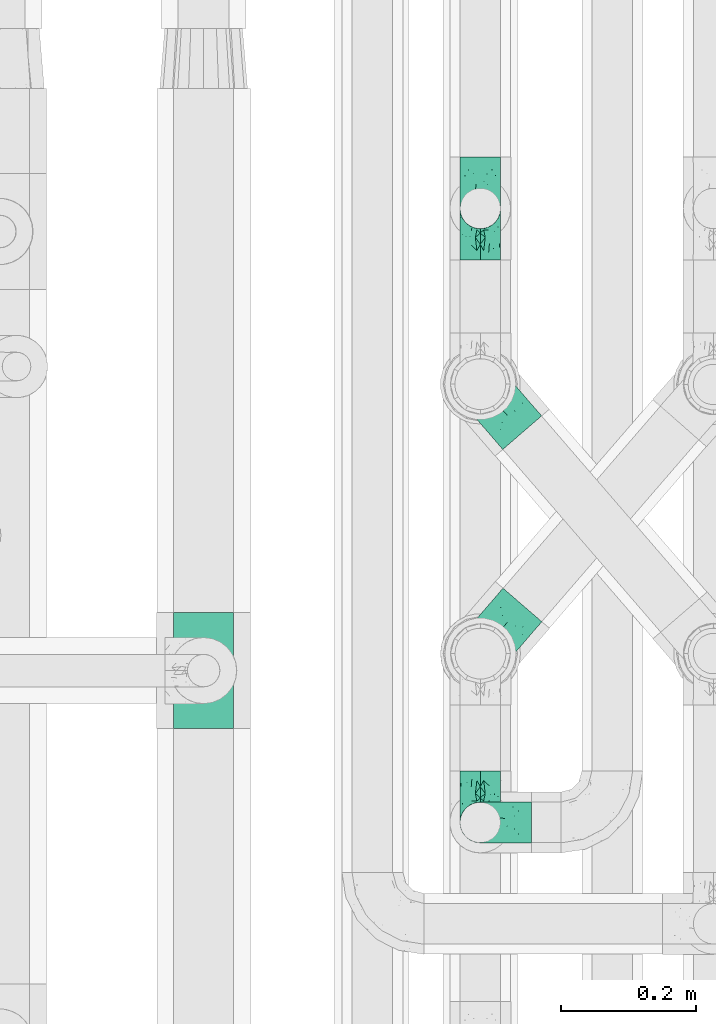
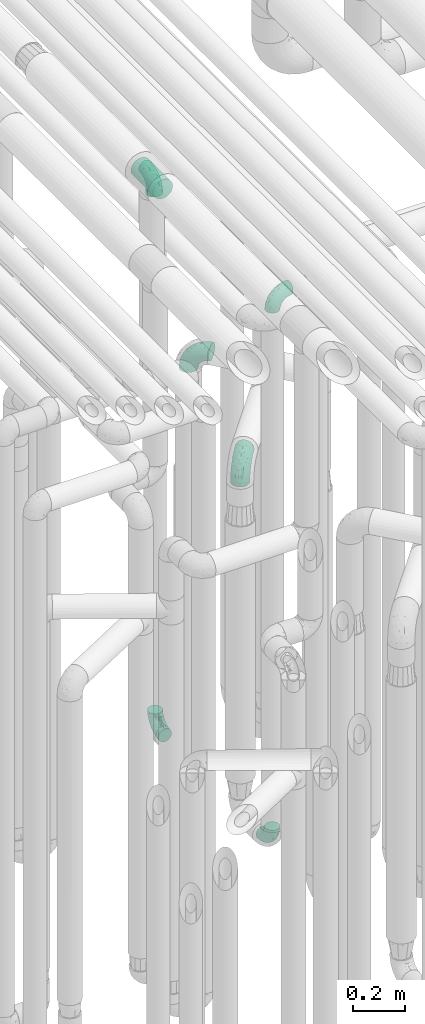
# One storey, part 623 of 827: 7 flow fittings.
"""IFC2X3 building model written with IfcOpenShell, lengths in millimetres."""

from ifc_helpers import new_model, entity, si_unit, converted_unit, derived_unit, direction, frame, origin, place, context, subcontext, project, spatial, faceted_brep, source, transform, mapped, material, type_object, type_shapes, element, save


model = new_model("IFC2X3")

# Units and contexts
model_context = context("Model", 3, precision=0.01, world=origin(), true_north=direction((6.12303176911189e-17, 1.0)))
body_context = subcontext(model_context, "Body", "Model", "MODEL_VIEW")
ifc_project = project(units=[si_unit("LENGTHUNIT", "METRE", prefix="MILLI"), si_unit("AREAUNIT", "SQUARE_METRE"), si_unit("VOLUMEUNIT", "CUBIC_METRE"), converted_unit("PLANEANGLEUNIT", "DEGREE", entity("IfcRatioMeasure", 0.0174532925199433), si_unit("PLANEANGLEUNIT", "RADIAN"), dimensions=[0, 0, 0, 0, 0, 0, 0]), si_unit("MASSUNIT", "GRAM", prefix="KILO"), derived_unit("MASSDENSITYUNIT", [(si_unit("MASSUNIT", "GRAM", prefix="KILO"), 1), (si_unit("LENGTHUNIT", "METRE"), -3)]), derived_unit("MOMENTOFINERTIAUNIT", [(si_unit("LENGTHUNIT", "METRE"), 4)]), si_unit("TIMEUNIT", "SECOND"), si_unit("FREQUENCYUNIT", "HERTZ"), si_unit("THERMODYNAMICTEMPERATUREUNIT", "DEGREE_CELSIUS"), derived_unit("THERMALTRANSMITTANCEUNIT", [(si_unit("MASSUNIT", "GRAM", prefix="KILO"), 1), (si_unit("THERMODYNAMICTEMPERATUREUNIT", "KELVIN"), -1), (si_unit("TIMEUNIT", "SECOND"), -3)]), derived_unit("VOLUMETRICFLOWRATEUNIT", [(si_unit("LENGTHUNIT", "METRE"), 3), (si_unit("TIMEUNIT", "SECOND"), -1)]), derived_unit("MASSFLOWRATEUNIT", [(si_unit("MASSUNIT", "GRAM", prefix="KILO"), 1), (si_unit("TIMEUNIT", "SECOND"), -1)]), derived_unit("ROTATIONALFREQUENCYUNIT", [(si_unit("TIMEUNIT", "SECOND"), -1)]), si_unit("ELECTRICCURRENTUNIT", "AMPERE"), si_unit("ELECTRICVOLTAGEUNIT", "VOLT"), si_unit("POWERUNIT", "WATT"), si_unit("FORCEUNIT", "NEWTON", prefix="KILO"), si_unit("ILLUMINANCEUNIT", "LUX"), si_unit("LUMINOUSFLUXUNIT", "LUMEN"), si_unit("LUMINOUSINTENSITYUNIT", "CANDELA"), derived_unit("USERDEFINED", [(si_unit("MASSUNIT", "GRAM", prefix="KILO"), -1), (si_unit("LENGTHUNIT", "METRE"), -2), (si_unit("TIMEUNIT", "SECOND"), 3), (si_unit("LUMINOUSFLUXUNIT", "LUMEN"), 1)]), derived_unit("LINEARVELOCITYUNIT", [(si_unit("LENGTHUNIT", "METRE"), 1), (si_unit("TIMEUNIT", "SECOND"), -1)]), si_unit("PRESSUREUNIT", "PASCAL"), derived_unit("USERDEFINED", [(si_unit("LENGTHUNIT", "METRE"), -2), (si_unit("MASSUNIT", "GRAM", prefix="KILO"), 1), (si_unit("TIMEUNIT", "SECOND"), -2)]), derived_unit("LINEARFORCEUNIT", [(si_unit("MASSUNIT", "GRAM", prefix="KILO"), 1), (si_unit("LENGTHUNIT", "METRE"), 1), (si_unit("TIMEUNIT", "SECOND"), -2), (si_unit("LENGTHUNIT", "METRE"), -1)]), derived_unit("PLANARFORCEUNIT", [(si_unit("MASSUNIT", "GRAM", prefix="KILO"), 1), (si_unit("LENGTHUNIT", "METRE"), 1), (si_unit("TIMEUNIT", "SECOND"), -2), (si_unit("LENGTHUNIT", "METRE"), -2)])], contexts=[model_context])

# Site, building, storey
site_placement = place(None, origin())
site = spatial("IfcSite", under=ifc_project, at=site_placement, CompositionType="ELEMENT")
building_placement = place(site_placement, origin())
building = spatial("IfcBuilding", under=site, at=building_placement, CompositionType="ELEMENT")
storey_placement = place(building_placement, frame((0.0, 0.0, 28200.0)))
storey = spatial("IfcBuildingStorey", under=building, at=storey_placement, Name="08", CompositionType="ELEMENT", Elevation=28200.0)

# Flow fittings
ifc_material = material()
pipe_fitting_type_1 = type_object("IfcPipeFittingType", Name="ADSK_1", PredefinedType="NOTDEFINED", material=ifc_material)
shared_shape_1 = source(origin(), body_context, "Body", "Brep", [
    faceted_brep([(-76.0, 15.07, -26.11), (-76.0, 7.8, -29.12), (-76.0, 0.0, -30.15), (-76.0, -7.8, -29.12), (-76.0, -15.08, -26.11), (-76.0, -21.32, -21.32), (-76.0, -26.11, -15.08), (-76.0, -29.12, -7.8), (-76.0, -30.15, 0.0), (-76.0, -29.12, 7.8), (-76.0, -26.11, 15.07), (-76.0, -21.32, 21.32), (-76.0, -15.08, 26.11), (-76.0, -7.8, 29.12), (-76.0, 0.0, 30.15), (-76.0, 7.8, 29.12), (-76.0, 15.07, 26.11), (-76.0, 21.32, 21.32), (-76.0, 26.11, 15.07), (-76.0, 29.12, 7.8), (-76.0, 30.15, 0.0), (-76.0, 29.12, -7.8), (-76.0, 26.11, -15.08), (-76.0, 21.32, -21.32), (0.0, 76.0, -30.15), (-7.8, 76.0, -29.12), (-15.07, 76.0, -26.11), (-21.32, 76.0, -21.32), (-26.11, 76.0, -15.08), (-29.12, 76.0, -7.8), (-30.15, 76.0, 0.0), (-29.12, 76.0, 7.8), (-26.11, 76.0, 15.07), (-21.32, 76.0, 21.32), (-15.07, 76.0, 26.11), (-7.8, 76.0, 29.12), (0.0, 76.0, 30.15), (7.8, 76.0, 29.12), (15.08, 76.0, 26.11), (21.32, 76.0, 21.32), (26.11, 76.0, 15.07), (29.12, 76.0, 7.8), (30.15, 76.0, 0.0), (29.12, 76.0, -7.8), (26.11, 76.0, -15.08), (21.32, 76.0, -21.32), (15.08, 76.0, -26.11), (7.8, 76.0, -29.12), (10.79, 31.43, 21.07), (4.32, 31.7, 25.72), (1.65, 15.19, 19.92), (-61.17, -27.8, 0.0), (-51.1, -25.49, 9.84), (-56.14, -10.61, 27.27), (-31.7, -4.32, 25.72), (-39.75, 1.72, 29.41), (-43.2, -24.95, 0.0), (-1.86, 1.86, 0.0), (4.49, 7.65, 5.78), (-7.82, -4.61, 5.83), (-56.21, -22.79, 17.21), (-58.98, -3.38, 29.7), (-53.96, 5.6, 30.07), (-10.86, 10.86, 25.48), (-17.2, -2.6, 20.44), (-49.15, -16.01, 22.7), (-22.18, -14.24, 7.99), (-28.4, -17.42, 0.0), (-13.61, -9.88, 0.0), (-39.0, 23.48, 27.76), (-58.76, 12.54, 28.36), (-41.61, 15.41, 29.48), (16.01, 49.15, 22.7), (-58.55, 25.93, 19.53), (-51.53, 33.5, 13.51), (-64.92, 28.76, 12.4), (-7.48, 23.14, 28.25), (-1.72, 39.75, 29.41), (-12.04, 27.88, 29.88), (-63.91, 18.81, 24.52), (-11.63, 65.16, 28.18), (-4.97, 57.02, 30.05), (9.88, 13.61, 0.0), (-62.5, 31.74, 5.02), (-45.17, 30.98, 21.2), (-21.78, 9.76, 28.58), (10.61, 56.14, 27.27), (-32.09, 54.42, 13.26), (22.79, 56.21, 17.21), (15.38, 31.17, 15.63), (25.49, 51.1, 9.84), (21.84, 36.35, 5.92), (24.95, 43.2, 0.0), (3.38, 58.98, 29.7), (-31.17, -15.38, 15.63), (-39.39, 41.78, 15.45), (-34.56, 41.13, 20.79), (-39.81, -23.25, 5.49), (27.8, 61.17, 0.0), (-31.74, 62.5, 5.02), (-53.07, 36.29, 0.0), (-42.95, 42.95, 7.29), (-36.29, 53.07, 0.0), (-19.83, 58.51, 24.79), (-25.48, 60.2, 19.41), (-14.53, 50.96, 28.57), (-13.31, 37.09, 30.07), (-26.16, 40.06, 26.4), (-32.43, -10.35, 21.9), (17.42, 28.4, 0.0), (14.24, 22.18, 7.99), (-38.67, 9.72, 30.15), (-24.66, 17.36, 30.09), (-37.08, 31.49, 24.99), (-49.27, 22.83, 25.24), (-20.8, 38.81, 28.63), (-27.58, 27.58, 29.2), (-36.07, -20.23, 10.71), (-15.19, -6.16, 14.9), (6.6, 15.4, 14.49), (-2.51, 2.51, 11.35), (-65.16, 11.63, -28.18), (-49.15, -16.01, -22.7), (-57.02, 4.97, -30.05), (-25.93, 58.55, -19.53), (-33.5, 51.53, -13.51), (-28.76, 64.92, -12.4), (-60.2, 25.48, -19.41), (-58.51, 19.83, -24.79), (4.61, 7.82, -5.83), (-7.65, -4.49, -5.78), (-2.51, 2.51, -11.35), (-62.5, 31.74, -5.02), (-50.96, 14.53, -28.57), (-37.09, 13.31, -30.07), (-42.95, 42.95, -7.29), (25.49, 51.1, -9.84), (22.79, 56.21, -17.21), (-40.06, 26.16, -26.4), (3.38, 58.98, -29.7), (-5.6, 53.96, -30.07), (-27.88, 12.04, -29.88), (-9.76, 21.78, -28.58), (-23.14, 7.48, -28.25), (-51.1, -25.49, -9.84), (15.38, 31.17, -15.63), (16.01, 49.15, -22.7), (-23.48, 39.0, -27.76), (-12.54, 58.76, -28.36), (-15.41, 41.61, -29.48), (-56.21, -22.79, -17.21), (-9.72, 38.67, -30.15), (-17.36, 24.66, -30.09), (-22.18, -14.24, -7.99), (-41.13, 34.56, -20.79), (-31.74, 62.5, -5.02), (-58.98, -3.38, -29.7), (-31.17, -15.38, -15.63), (-56.14, -10.61, -27.27), (14.24, 22.18, -7.99), (23.25, 39.81, -5.49), (-31.49, 37.08, -24.99), (-15.19, -6.16, -14.9), (1.65, 15.19, -19.92), (-18.81, 63.91, -24.52), (-32.59, -11.62, -20.84), (-31.7, -4.32, -25.72), (-17.2, -2.6, -20.44), (-39.75, 1.72, -29.41), (-54.42, 32.09, -13.26), (-30.98, 45.17, -21.2), (10.61, 56.14, -27.27), (10.23, 31.31, -21.52), (4.32, 31.7, -25.72), (-41.78, 39.39, -15.45), (-1.72, 39.75, -29.41), (-36.35, -21.84, -5.92), (-22.83, 49.27, -25.24), (-38.81, 20.8, -28.63), (-27.58, 27.58, -29.2), (-10.86, 10.86, -25.48), (20.23, 36.07, -10.71), (6.6, 15.4, -14.49)], [[[0, 1, 2, 3, 4, 5, 6, 7, 8, 9, 10, 11, 12, 13, 14, 15, 16, 17, 18, 19, 20, 21, 22, 23]], [[24, 25, 26, 27, 28, 29, 30, 31, 32, 33, 34, 35, 36, 37, 38, 39, 40, 41, 42, 43, 44, 45, 46, 47]], [[48, 49, 50]], [[51, 52, 9]], [[53, 54, 55]], [[9, 52, 10]], [[56, 52, 51]], [[57, 58, 59]], [[11, 10, 60]], [[14, 61, 62]], [[63, 54, 64]], [[65, 12, 11]], [[65, 53, 12]], [[66, 67, 68]], [[69, 70, 71]], [[72, 39, 38]], [[73, 74, 75]], [[15, 70, 16]], [[76, 77, 78]], [[16, 79, 17]], [[13, 61, 14]], [[35, 80, 81]], [[14, 62, 15]], [[17, 73, 18]], [[57, 82, 58]], [[20, 19, 83]], [[75, 19, 18]], [[70, 15, 62]], [[73, 84, 74]], [[78, 85, 76]], [[38, 86, 72]], [[32, 31, 87]], [[88, 89, 90]], [[91, 92, 90]], [[72, 86, 49]], [[36, 93, 37]], [[75, 83, 19]], [[36, 35, 81]], [[60, 94, 65]], [[40, 90, 41]], [[95, 96, 87]], [[88, 90, 40]], [[66, 97, 67]], [[90, 98, 41]], [[40, 39, 88]], [[99, 31, 30]], [[20, 83, 100]], [[101, 102, 100]], [[52, 60, 10]], [[102, 99, 30]], [[96, 103, 104]], [[83, 101, 100]], [[12, 53, 13]], [[104, 103, 33]], [[105, 106, 81]], [[107, 105, 103]], [[64, 54, 108]], [[80, 103, 105]], [[80, 35, 34]], [[34, 33, 103]], [[86, 38, 37]], [[109, 110, 82]], [[71, 111, 112]], [[69, 107, 113]], [[79, 73, 17]], [[114, 113, 84]], [[33, 32, 104]], [[115, 107, 116]], [[105, 115, 106]], [[93, 81, 77]], [[54, 53, 65]], [[61, 53, 55]], [[108, 94, 64]], [[54, 63, 85]], [[93, 86, 37]], [[77, 76, 49]], [[77, 49, 86]], [[49, 63, 50]], [[60, 52, 117]], [[65, 11, 60]], [[39, 72, 88]], [[89, 88, 72]], [[71, 70, 62]], [[79, 70, 114]], [[103, 96, 107]], [[69, 113, 114]], [[112, 106, 116]], [[77, 81, 106]], [[112, 116, 71]], [[112, 55, 85]], [[64, 50, 63]], [[57, 59, 68]], [[32, 87, 104]], [[96, 104, 87]], [[94, 118, 64]], [[50, 119, 89]], [[50, 64, 118]], [[50, 89, 48]], [[81, 93, 36]], [[86, 93, 77]], [[53, 61, 13]], [[62, 61, 55]], [[71, 62, 111]], [[69, 71, 116]], [[95, 101, 74]], [[99, 101, 87]], [[118, 66, 59]], [[117, 97, 66]], [[117, 66, 94]], [[91, 89, 110]], [[91, 110, 109]], [[110, 89, 119]], [[9, 8, 51]], [[98, 90, 92]], [[98, 42, 41]], [[101, 83, 74]], [[101, 99, 102]], [[87, 31, 99]], [[62, 55, 111]], [[55, 112, 111]], [[107, 69, 116]], [[70, 69, 114]], [[107, 96, 113]], [[84, 113, 96]], [[84, 96, 95]], [[114, 84, 73]], [[70, 79, 16]], [[73, 79, 114]], [[54, 85, 55]], [[76, 85, 63]], [[49, 76, 63]], [[77, 106, 78]], [[106, 112, 78]], [[85, 78, 112]], [[73, 75, 18]], [[83, 75, 74]], [[103, 80, 34]], [[81, 80, 105]], [[101, 95, 87]], [[84, 95, 74]], [[106, 115, 116]], [[105, 107, 115]], [[120, 59, 58]], [[82, 110, 58]], [[119, 58, 110]], [[118, 59, 120]], [[66, 68, 59]], [[54, 65, 108]], [[94, 108, 65]], [[66, 118, 94]], [[50, 118, 120]], [[50, 120, 119]], [[119, 120, 58]], [[89, 72, 48]], [[49, 48, 72]], [[60, 117, 94]], [[117, 52, 97]], [[52, 56, 97]], [[67, 97, 56]], [[92, 91, 109]], [[89, 91, 90]], [[121, 1, 0]], [[122, 5, 4]], [[2, 1, 123]], [[124, 125, 126]], [[127, 128, 23]], [[129, 130, 131]], [[100, 132, 20]], [[133, 134, 123]], [[135, 100, 102]], [[136, 137, 44]], [[133, 128, 138]], [[24, 139, 140]], [[141, 142, 143]], [[121, 128, 133]], [[6, 144, 7]], [[137, 145, 146]], [[144, 51, 7]], [[147, 148, 149]], [[144, 6, 150]], [[149, 151, 152]], [[153, 68, 67]], [[154, 128, 127]], [[30, 155, 102]], [[43, 42, 98]], [[156, 3, 2]], [[157, 144, 150]], [[158, 4, 3]], [[24, 140, 25]], [[155, 135, 102]], [[159, 160, 109]], [[30, 29, 155]], [[147, 138, 161]], [[27, 124, 28]], [[57, 129, 82]], [[162, 163, 131]], [[27, 26, 164]], [[148, 26, 25]], [[165, 166, 167]], [[24, 47, 139]], [[143, 168, 141]], [[22, 21, 169]], [[125, 124, 170]], [[148, 25, 140]], [[46, 146, 171]], [[158, 122, 4]], [[0, 23, 128]], [[1, 121, 123]], [[109, 82, 159]], [[45, 44, 137]], [[146, 46, 45]], [[136, 43, 98]], [[132, 21, 20]], [[136, 98, 92]], [[172, 173, 146]], [[46, 171, 47]], [[43, 136, 44]], [[174, 154, 169]], [[171, 173, 175]], [[6, 5, 150]], [[126, 29, 28]], [[176, 56, 144]], [[122, 158, 166]], [[164, 124, 27]], [[177, 161, 170]], [[23, 22, 127]], [[178, 138, 179]], [[133, 178, 134]], [[156, 123, 168]], [[156, 158, 3]], [[168, 143, 166]], [[168, 166, 158]], [[166, 180, 167]], [[173, 171, 146]], [[139, 171, 175]], [[172, 145, 163]], [[173, 180, 142]], [[5, 122, 150]], [[157, 150, 122]], [[137, 136, 181]], [[146, 45, 137]], [[149, 148, 140]], [[164, 148, 177]], [[128, 154, 138]], [[147, 161, 177]], [[152, 134, 179]], [[168, 123, 134]], [[152, 179, 149]], [[152, 175, 142]], [[57, 130, 129]], [[157, 165, 167]], [[22, 169, 127]], [[154, 127, 169]], [[163, 167, 180]], [[162, 157, 167]], [[173, 163, 180]], [[182, 163, 145]], [[123, 156, 2]], [[158, 156, 168]], [[171, 139, 47]], [[140, 139, 175]], [[149, 140, 151]], [[147, 149, 179]], [[174, 135, 125]], [[132, 135, 169]], [[176, 157, 153]], [[176, 153, 67]], [[153, 157, 162]], [[182, 159, 129]], [[181, 160, 159]], [[181, 159, 145]], [[51, 144, 56]], [[51, 8, 7]], [[135, 132, 100]], [[169, 21, 132]], [[126, 155, 29]], [[135, 155, 125]], [[140, 175, 151]], [[175, 152, 151]], [[138, 147, 179]], [[148, 147, 177]], [[138, 154, 161]], [[170, 161, 154]], [[170, 154, 174]], [[177, 170, 124]], [[148, 164, 26]], [[124, 164, 177]], [[173, 142, 175]], [[143, 142, 180]], [[166, 143, 180]], [[168, 134, 141]], [[134, 152, 141]], [[142, 141, 152]], [[124, 126, 28]], [[155, 126, 125]], [[128, 121, 0]], [[123, 121, 133]], [[135, 174, 169]], [[170, 174, 125]], [[134, 178, 179]], [[133, 138, 178]], [[130, 153, 162]], [[68, 153, 130]], [[57, 68, 130]], [[182, 129, 131]], [[159, 82, 129]], [[157, 122, 165]], [[166, 165, 122]], [[163, 162, 167]], [[162, 131, 130]], [[145, 172, 146]], [[163, 173, 172]], [[159, 182, 145]], [[131, 163, 182]], [[56, 176, 67]], [[157, 176, 144]], [[137, 181, 145]], [[181, 136, 160]], [[136, 92, 160]], [[109, 160, 92]]]),
])
type_shapes(pipe_fitting_type_1, [shared_shape_1])
for number, where, z_axis, x_axis, name in (
    (1, (36629.64, 13240.2, 3000.0), (1.0, 0.0, 0.0), (0.0, -1.0, 0.0), "ADSK_1"),
    (2, (36629.64, 13240.2, 400.0), (-1.0, 0.0, 0.0), (0.0, 0.0, -1.0), "ADSK_1"),
    (3, (36629.64, 12331.17, 400.0), (-1.0, 0.0, 0.0), (0.0, -1.0, 0.0), "ADSK_1"),
    (4, (36629.64, 12331.17, 3000.0), (0.0, -1.0, 0.0), (-1.0, 0.0, 0.0), "ADSK_1"),
):
    element("IfcFlowFitting", number, at=place(storey_placement, frame(where, z_axis=z_axis, x_axis=x_axis)), inside=storey, type_object=pipe_fitting_type_1, material=ifc_material, Name=name, ObjectType="ADSK_1", context=body_context, shape_type="MappedRepresentation", body=[
        mapped(shared_shape_1, transform((0.0, 0.0, 0.0), scale=1.0)),
    ])
pipe_fitting_type_2 = type_object("IfcPipeFittingType", Name="ADSK_1", PredefinedType="NOTDEFINED", material=ifc_material)
shared_shape_2 = source(origin(), body_context, "Body", "Brep", [
    faceted_brep([(-95.0, 19.02, -32.95), (-95.0, 9.85, -36.75), (-95.0, 0.0, -38.05), (-95.0, -9.85, -36.75), (-95.0, -19.03, -32.95), (-95.0, -26.91, -26.91), (-95.0, -32.95, -19.03), (-95.0, -36.75, -9.85), (-95.0, -38.05, 0.0), (-95.0, -36.75, 9.85), (-95.0, -32.95, 19.02), (-95.0, -26.91, 26.91), (-95.0, -19.03, 32.95), (-95.0, -9.85, 36.75), (-95.0, 0.0, 38.05), (-95.0, 9.85, 36.75), (-95.0, 19.02, 32.95), (-95.0, 26.91, 26.91), (-95.0, 32.95, 19.02), (-95.0, 36.75, 9.85), (-95.0, 38.05, 0.0), (-95.0, 36.75, -9.85), (-95.0, 32.95, -19.03), (-95.0, 26.91, -26.91), (0.0, 95.0, -38.05), (-9.85, 95.0, -36.75), (-19.02, 95.0, -32.95), (-26.91, 95.0, -26.91), (-32.95, 95.0, -19.03), (-36.75, 95.0, -9.85), (-38.05, 95.0, 0.0), (-36.75, 95.0, 9.85), (-32.95, 95.0, 19.02), (-26.91, 95.0, 26.91), (-19.02, 95.0, 32.95), (-9.85, 95.0, 36.75), (0.0, 95.0, 38.05), (9.85, 95.0, 36.75), (19.03, 95.0, 32.95), (26.91, 95.0, 26.91), (32.95, 95.0, 19.02), (36.75, 95.0, 9.85), (38.05, 95.0, 0.0), (36.75, 95.0, -9.85), (32.95, 95.0, -19.03), (26.91, 95.0, -26.91), (19.03, 95.0, -32.95), (9.85, 95.0, -36.75), (-7.99, -4.96, 6.3), (-0.92, 0.92, 0.0), (4.62, 8.1, 8.01), (-76.19, -35.57, 0.0), (-64.32, -32.32, 12.43), (20.51, 62.45, 28.68), (-60.56, -33.52, 0.0), (-70.4, -13.47, 34.42), (-39.61, -5.88, 32.32), (-49.6, 2.07, 37.1), (-70.34, -28.81, 21.71), (14.64, 40.81, 26.5), (5.88, 39.61, 32.32), (3.59, 20.77, 25.31), (-40.45, 68.06, 16.75), (-62.45, -20.51, 28.68), (-44.52, -26.87, 0.0), (-28.47, -20.22, 0.0), (-26.43, -17.83, 8.75), (-76.1, 39.63, 10.76), (-72.74, 37.58, 18.19), (-60.35, 46.18, 14.61), (-13.4, 13.4, 32.12), (-20.77, -3.59, 25.31), (-14.66, 81.47, 35.56), (-6.22, 71.26, 37.92), (-57.5, 42.48, 22.79), (-15.0, 34.74, 37.7), (-27.1, 12.08, 36.05), (-9.2, 28.81, 35.63), (-79.98, 23.7, 30.95), (-73.68, -4.3, 37.48), (-30.74, 21.67, 37.97), (-62.36, 47.59, 6.79), (-72.71, 32.83, 24.69), (-67.42, 7.02, 37.95), (-32.13, 75.27, 24.51), (-43.46, 51.47, 26.26), (-24.98, 73.15, 31.29), (20.59, 41.28, 19.85), (7.79, 16.09, 15.86), (-73.21, 42.39, 0.0), (-54.73, 54.73, 0.0), (-73.44, 15.79, 35.79), (-5.94, 4.32, 20.43), (28.81, 70.34, 21.71), (32.32, 64.32, 12.43), (-53.59, 26.2, 35.09), (-52.02, 19.31, 37.21), (21.38, 33.53, 10.34), (26.87, 44.52, 0.0), (-48.28, 12.14, 38.05), (4.3, 73.68, 37.48), (-44.08, -25.52, 12.79), (-41.28, -20.59, 19.85), (35.57, 76.19, 0.0), (-47.26, 54.3, 20.18), (-47.4, 61.99, 8.58), (-42.39, 73.21, 0.0), (-39.67, 78.86, 7.21), (-45.69, 36.84, 33.11), (-32.83, 50.13, 33.35), (13.47, 70.4, 34.42), (-18.25, 63.73, 36.07), (-40.63, -13.75, 27.22), (-16.63, 46.37, 37.95), (-53.47, 38.79, 28.59), (-26.07, 48.54, 36.15), (-34.51, 34.51, 36.86), (-2.07, 49.6, 37.1), (-22.79, -10.49, 19.23), (-61.73, 28.67, 31.87), (9.65, 14.7, 0.0), (20.22, 28.47, 0.0), (33.52, 60.56, 0.0), (-11.42, -5.44, 13.25), (-14.7, -9.65, 0.0), (-81.47, 14.66, -35.56), (-62.45, -20.51, -28.68), (-71.26, 6.22, -37.92), (-75.27, 32.13, -24.51), (-73.15, 24.98, -31.29), (13.47, 70.4, -34.42), (5.88, 39.61, -32.32), (-2.07, 49.6, -37.1), (-78.86, 39.67, -7.21), (-70.4, -13.47, -34.42), (-39.61, -5.88, -32.32), (-61.99, 47.4, -8.58), (32.32, 64.32, -12.43), (28.81, 70.34, -21.71), (-63.73, 18.25, -36.07), (-50.13, 32.83, -33.35), (4.3, 73.68, -37.48), (-7.02, 67.42, -37.95), (-39.63, 76.1, -10.76), (-46.18, 60.35, -14.61), (-47.59, 62.36, -6.79), (-64.32, -32.32, -12.43), (-26.2, 53.59, -35.09), (-15.79, 73.44, -35.79), (-19.31, 52.02, -37.21), (-37.58, 72.74, -18.19), (-70.34, -28.81, -21.71), (-42.48, 57.5, -22.79), (-38.79, 53.47, -28.59), (-51.47, 43.46, -26.26), (-32.83, 72.71, -24.69), (-46.37, 16.63, -37.95), (-73.68, -4.3, -37.48), (-41.28, -20.59, -19.85), (-44.08, -25.52, -12.79), (13.75, 40.63, -27.22), (20.51, 62.45, -28.68), (-68.06, 40.45, -16.75), (-54.3, 47.26, -20.18), (-12.14, 48.28, -38.05), (-21.67, 30.74, -37.97), (-36.84, 45.69, -33.11), (-11.42, -5.44, -13.25), (7.79, 16.09, -15.86), (4.62, 8.1, -8.01), (-23.7, 79.98, -30.95), (-26.43, -17.83, -8.75), (-7.99, -4.96, -6.3), (-40.81, -14.64, -26.5), (-20.77, -3.59, -25.31), (-34.74, 15.0, -37.7), (-12.08, 27.1, -36.05), (-28.81, 9.2, -35.63), (-22.79, -10.49, -19.23), (21.38, 33.53, -10.34), (20.59, 41.28, -19.85), (-48.54, 26.07, -36.15), (-49.6, 2.07, -37.1), (-13.4, 13.4, -32.12), (3.59, 20.77, -25.31), (-28.67, 61.73, -31.87), (-34.51, 34.51, -36.86), (-5.94, 4.32, -20.43)], [[[0, 1, 2, 3, 4, 5, 6, 7, 8, 9, 10, 11, 12, 13, 14, 15, 16, 17, 18, 19, 20, 21, 22, 23]], [[24, 25, 26, 27, 28, 29, 30, 31, 32, 33, 34, 35, 36, 37, 38, 39, 40, 41, 42, 43, 44, 45, 46, 47]], [[48, 49, 50]], [[51, 52, 9]], [[53, 39, 38]], [[9, 52, 10]], [[54, 52, 51]], [[55, 56, 57]], [[11, 10, 58]], [[59, 60, 61]], [[32, 31, 62]], [[63, 12, 11]], [[63, 55, 12]], [[64, 65, 66]], [[67, 68, 69]], [[70, 56, 71]], [[35, 72, 73]], [[69, 68, 74]], [[75, 76, 77]], [[16, 78, 17]], [[13, 79, 14]], [[76, 75, 80]], [[67, 69, 81]], [[18, 17, 82]], [[14, 79, 83]], [[20, 19, 67]], [[84, 85, 86]], [[87, 61, 88]], [[89, 81, 90]], [[18, 82, 68]], [[15, 91, 16]], [[14, 83, 15]], [[71, 92, 61]], [[17, 78, 82]], [[93, 87, 94]], [[95, 91, 96]], [[97, 98, 94]], [[86, 72, 34]], [[96, 99, 80]], [[37, 36, 100]], [[40, 39, 93]], [[40, 94, 41]], [[64, 66, 101]], [[93, 94, 40]], [[58, 102, 63]], [[94, 103, 41]], [[94, 87, 97]], [[104, 69, 74]], [[34, 33, 86]], [[105, 69, 104]], [[52, 58, 10]], [[106, 107, 30]], [[108, 109, 85]], [[105, 106, 90]], [[53, 110, 60]], [[86, 111, 72]], [[86, 109, 111]], [[33, 84, 86]], [[12, 55, 13]], [[112, 56, 63]], [[110, 38, 37]], [[34, 72, 35]], [[36, 35, 73]], [[111, 113, 73]], [[105, 107, 106]], [[110, 53, 38]], [[74, 114, 85]], [[91, 15, 83]], [[105, 90, 81]], [[107, 62, 31]], [[33, 32, 84]], [[115, 109, 116]], [[111, 115, 113]], [[100, 73, 117]], [[56, 55, 63]], [[79, 55, 57]], [[102, 118, 112]], [[56, 70, 76]], [[100, 110, 37]], [[117, 77, 60]], [[117, 60, 110]], [[60, 70, 61]], [[58, 52, 101]], [[63, 11, 58]], [[39, 53, 93]], [[87, 93, 53]], [[96, 91, 83]], [[78, 91, 119]], [[32, 62, 84]], [[84, 62, 104]], [[86, 85, 109]], [[85, 114, 108]], [[80, 113, 116]], [[117, 73, 113]], [[80, 116, 96]], [[80, 57, 76]], [[71, 112, 118]], [[61, 87, 59]], [[62, 107, 105]], [[97, 120, 121]], [[70, 71, 61]], [[71, 118, 92]], [[73, 100, 36]], [[110, 100, 117]], [[55, 79, 13]], [[83, 79, 57]], [[96, 83, 99]], [[116, 108, 95]], [[50, 97, 88]], [[97, 87, 88]], [[50, 49, 120]], [[122, 94, 98]], [[89, 20, 67]], [[105, 81, 69]], [[89, 67, 81]], [[68, 19, 18]], [[68, 67, 19]], [[74, 68, 82]], [[114, 82, 119]], [[74, 85, 104]], [[82, 114, 74]], [[114, 119, 108]], [[95, 108, 119]], [[116, 109, 108]], [[123, 48, 50]], [[97, 50, 120]], [[123, 50, 88]], [[91, 95, 119]], [[116, 95, 96]], [[84, 104, 85]], [[104, 62, 105]], [[83, 57, 99]], [[57, 80, 99]], [[66, 48, 123]], [[66, 124, 48]], [[118, 66, 123]], [[124, 66, 65]], [[66, 118, 101]], [[54, 64, 52]], [[124, 49, 48]], [[30, 107, 31]], [[91, 78, 16]], [[82, 78, 119]], [[56, 76, 57]], [[77, 76, 70]], [[60, 77, 70]], [[77, 117, 75]], [[117, 113, 75]], [[113, 80, 75]], [[9, 8, 51]], [[103, 94, 122]], [[103, 42, 41]], [[73, 72, 111]], [[113, 115, 116]], [[111, 109, 115]], [[102, 112, 63]], [[71, 56, 112]], [[118, 102, 101]], [[92, 123, 88]], [[123, 92, 118]], [[61, 92, 88]], [[87, 53, 59]], [[60, 59, 53]], [[97, 121, 98]], [[58, 101, 102]], [[64, 101, 52]], [[125, 1, 0]], [[126, 5, 4]], [[2, 1, 127]], [[1, 125, 127]], [[128, 129, 23]], [[130, 131, 132]], [[89, 133, 20]], [[126, 134, 135]], [[136, 89, 90]], [[137, 138, 44]], [[139, 129, 140]], [[24, 141, 142]], [[143, 144, 145]], [[125, 129, 139]], [[6, 146, 7]], [[147, 148, 149]], [[146, 51, 7]], [[143, 150, 144]], [[146, 6, 151]], [[152, 153, 154]], [[126, 4, 134]], [[0, 23, 129]], [[28, 155, 150]], [[43, 42, 103]], [[54, 146, 64]], [[139, 156, 127]], [[157, 3, 2]], [[151, 158, 159]], [[160, 131, 161]], [[22, 21, 162]], [[136, 144, 163]], [[149, 164, 165]], [[24, 142, 25]], [[166, 140, 154]], [[154, 129, 128]], [[143, 30, 29]], [[167, 168, 169]], [[155, 28, 27]], [[26, 170, 27]], [[171, 167, 172]], [[26, 25, 148]], [[27, 170, 155]], [[173, 135, 174]], [[144, 150, 152]], [[175, 176, 177]], [[24, 47, 141]], [[45, 161, 46]], [[148, 25, 142]], [[176, 175, 165]], [[64, 159, 171]], [[138, 45, 44]], [[130, 46, 161]], [[137, 44, 43]], [[178, 159, 158]], [[137, 103, 122]], [[163, 144, 152]], [[136, 133, 89]], [[103, 137, 43]], [[6, 5, 151]], [[178, 158, 173]], [[134, 4, 3]], [[178, 173, 174]], [[137, 98, 179]], [[145, 90, 106]], [[138, 180, 161]], [[46, 130, 47]], [[136, 90, 145]], [[133, 162, 21]], [[23, 22, 128]], [[139, 140, 181]], [[139, 181, 156]], [[157, 127, 182]], [[157, 134, 3]], [[182, 177, 135]], [[182, 135, 134]], [[135, 183, 174]], [[131, 130, 161]], [[141, 130, 132]], [[160, 180, 184]], [[131, 183, 176]], [[5, 126, 151]], [[158, 151, 126]], [[180, 138, 137]], [[161, 45, 138]], [[149, 148, 142]], [[170, 148, 185]], [[22, 162, 128]], [[128, 162, 163]], [[129, 154, 140]], [[154, 153, 166]], [[165, 156, 186]], [[182, 127, 156]], [[165, 186, 149]], [[165, 132, 176]], [[131, 184, 183]], [[187, 167, 178]], [[184, 168, 187]], [[167, 169, 172]], [[184, 180, 168]], [[174, 183, 184]], [[127, 157, 2]], [[134, 157, 182]], [[130, 141, 47]], [[142, 141, 132]], [[149, 142, 164]], [[186, 166, 147]], [[180, 179, 168]], [[169, 179, 120]], [[137, 179, 180]], [[179, 121, 120]], [[106, 30, 143]], [[136, 145, 144]], [[106, 143, 145]], [[150, 29, 28]], [[150, 143, 29]], [[152, 150, 155]], [[153, 155, 185]], [[152, 154, 163]], [[155, 153, 152]], [[153, 185, 166]], [[147, 166, 185]], [[186, 140, 166]], [[169, 120, 49]], [[169, 49, 172]], [[179, 169, 168]], [[148, 147, 185]], [[186, 147, 149]], [[128, 163, 154]], [[163, 162, 136]], [[142, 132, 164]], [[132, 165, 164]], [[171, 124, 65]], [[124, 171, 172]], [[64, 146, 159]], [[171, 159, 178]], [[171, 65, 64]], [[172, 49, 124]], [[162, 133, 136]], [[20, 133, 21]], [[148, 170, 26]], [[155, 170, 185]], [[131, 176, 132]], [[177, 176, 183]], [[135, 177, 183]], [[177, 182, 175]], [[182, 156, 175]], [[156, 165, 175]], [[51, 146, 54]], [[51, 8, 7]], [[129, 125, 0]], [[127, 125, 139]], [[140, 186, 181]], [[156, 181, 186]], [[158, 126, 173]], [[135, 173, 126]], [[187, 178, 174]], [[171, 178, 167]], [[184, 187, 174]], [[167, 187, 168]], [[180, 160, 161]], [[184, 131, 160]], [[98, 137, 122]], [[98, 121, 179]], [[151, 159, 146]]]),
])
type_shapes(pipe_fitting_type_2, [shared_shape_2])
for number, where, z_axis, x_axis, name in (
    (5, (36629.64, 12980.2, 2350.0), (0.756847522306242, 0.65359148401651, 0.0), (0.0, 0.0, 1.0), "ADSK_1"),
    (6, (36629.92, 12581.35, 2050.0), (-0.756825266247892, 0.653617255256322, 0.0), (0.0, 0.0, 1.0), "ADSK_1"),
):
    element("IfcFlowFitting", number, at=place(storey_placement, frame(where, z_axis=z_axis, x_axis=x_axis)), inside=storey, type_object=pipe_fitting_type_2, material=ifc_material, Name=name, ObjectType="ADSK_1", context=body_context, shape_type="MappedRepresentation", body=[
        mapped(shared_shape_2, transform((0.0, 0.0, 0.0), scale=1.0)),
    ])
pipe_fitting_type_3 = type_object("IfcPipeFittingType", Name="ADSK_1", PredefinedType="NOTDEFINED", material=ifc_material)
shared_shape_3 = source(origin(), body_context, "Body", "Brep", [
    faceted_brep([(-86.0, 22.22, -38.49), (-86.0, 11.5, -42.94), (-86.0, 0.0, -44.45), (-86.0, -11.5, -42.94), (-86.0, -22.23, -38.49), (-86.0, -31.43, -31.43), (-86.0, -38.49, -22.23), (-86.0, -42.94, -11.5), (-86.0, -44.45, 0.0), (-86.0, -42.94, 11.5), (-86.0, -38.49, 22.22), (-86.0, -31.43, 31.43), (-86.0, -22.23, 38.49), (-86.0, -11.5, 42.94), (-86.0, 0.0, 44.45), (-86.0, 11.5, 42.94), (-86.0, 22.22, 38.49), (-86.0, 31.43, 31.43), (-86.0, 38.49, 22.22), (-86.0, 42.94, 11.5), (-86.0, 44.45, 0.0), (-86.0, 42.94, -11.5), (-86.0, 38.49, -22.23), (-86.0, 31.43, -31.43), (86.0, 0.0, -44.45), (86.0, 11.5, -42.94), (86.0, 22.22, -38.49), (86.0, 31.43, -31.43), (86.0, 38.49, -22.23), (86.0, 42.94, -11.5), (86.0, 44.45, 0.0), (86.0, 42.94, 11.5), (86.0, 38.49, 22.22), (86.0, 31.43, 31.43), (86.0, 22.22, 38.49), (86.0, 11.5, 42.94), (86.0, 0.0, 44.45), (86.0, -11.5, 42.94), (86.0, -22.23, 38.49), (86.0, -31.43, 31.43), (86.0, -38.49, 22.22), (86.0, -42.94, 11.5), (86.0, -44.45, 0.0), (86.0, -42.94, -11.5), (86.0, -38.49, -22.23), (86.0, -31.43, -31.43), (86.0, -22.23, -38.49), (86.0, -11.5, -42.94), (22.65, -43.65, 8.39), (23.4, -44.05, 4.19), (24.15, -44.45, 0.0), (18.45, -41.63, 15.58), (4.27, -37.56, 23.77), (12.15, -39.25, 20.87), (8.21, -38.4, 22.32), (-24.15, -44.45, 0.0), (-23.4, -44.05, 4.19), (-22.65, -43.65, 8.38), (-18.46, -41.63, 15.57), (-12.16, -39.25, 20.87), (-8.22, -38.4, 22.32), (-4.28, -37.56, 23.77), (0.0, -37.56, 23.77), (4.27, -37.56, -23.77), (12.15, -39.25, -20.87), (8.21, -38.4, -22.32), (18.45, -41.63, -15.58), (22.65, -43.65, -8.39), (23.4, -44.05, -4.19), (-4.28, -37.56, -23.77), (-8.22, -38.4, -22.32), (-12.16, -39.25, -20.87), (-18.46, -41.63, -15.57), (0.0, -37.56, -23.77), (-22.65, -43.65, -8.38), (-23.4, -44.05, -4.19), (0.0, -73.0, -24.15), (6.25, -73.0, -23.33), (12.08, -73.0, -20.91), (17.08, -73.0, -17.08), (20.91, -73.0, -12.08), (23.33, -73.0, -6.25), (24.15, -73.0, 0.0), (23.33, -73.0, 6.25), (20.91, -73.0, 12.07), (17.08, -73.0, 17.08), (12.08, -73.0, 20.91), (6.25, -73.0, 23.33), (0.0, -73.0, 24.15), (-6.25, -73.0, 23.33), (-12.07, -73.0, 20.91), (-17.08, -73.0, 17.08), (-20.91, -73.0, 12.07), (-23.33, -73.0, 6.25), (-24.15, -73.0, 0.0), (-23.33, -73.0, -6.25), (-20.91, -73.0, -12.08), (-17.08, -73.0, -17.08), (-12.07, -73.0, -20.91), (-6.25, -73.0, -23.33)], [[[0, 1, 2, 3, 4, 5, 6, 7, 8, 9, 10, 11, 12, 13, 14, 15, 16, 17, 18, 19, 20, 21, 22, 23]], [[24, 25, 26, 27, 28, 29, 30, 31, 32, 33, 34, 35, 36, 37, 38, 39, 40, 41, 42, 43, 44, 45, 46, 47]], [[42, 41, 48]], [[42, 48, 49, 50]], [[41, 51, 48]], [[40, 39, 52]], [[53, 51, 40]], [[40, 52, 54, 53]], [[39, 11, 52]], [[40, 51, 41]], [[8, 55, 56, 57]], [[9, 8, 57]], [[57, 58, 9]], [[10, 59, 60, 61]], [[59, 10, 58]], [[10, 61, 11]], [[58, 10, 9]], [[11, 61, 62, 52]], [[39, 38, 12, 11]], [[14, 13, 37, 36]], [[13, 12, 38, 37]], [[15, 14, 36, 35]], [[32, 31, 19, 18]], [[17, 16, 34, 33]], [[18, 17, 33, 32]], [[35, 34, 16, 15]], [[20, 19, 31, 30]], [[29, 28, 22, 21]], [[28, 27, 23, 22]], [[30, 29, 21, 20]], [[24, 47, 3, 2]], [[1, 0, 26, 25]], [[2, 1, 25, 24]], [[27, 26, 0, 23]], [[4, 3, 47, 46]], [[46, 45, 5, 4]], [[45, 44, 63]], [[44, 64, 65, 63]], [[44, 66, 64]], [[45, 63, 5]], [[43, 42, 67]], [[67, 66, 43]], [[42, 50, 68, 67]], [[43, 66, 44]], [[6, 69, 70, 71]], [[6, 5, 69]], [[71, 72, 6]], [[5, 63, 73, 69]], [[72, 74, 7]], [[74, 8, 7]], [[8, 74, 75, 55]], [[72, 7, 6]], [[76, 77, 78, 79, 80, 81, 82, 83, 84, 85, 86, 87, 88, 89, 90, 91, 92, 93, 94, 95, 96, 97, 98, 99]], [[93, 56, 94]], [[88, 61, 89]], [[60, 90, 89]], [[60, 59, 90]], [[86, 54, 87]], [[93, 57, 56]], [[49, 82, 50]], [[57, 93, 92]], [[56, 55, 94]], [[57, 92, 58]], [[90, 59, 91]], [[89, 61, 60]], [[91, 59, 58]], [[91, 58, 92]], [[88, 52, 62, 61]], [[86, 53, 54]], [[85, 53, 86]], [[48, 84, 83]], [[85, 84, 51]], [[52, 88, 87]], [[54, 52, 87]], [[53, 85, 51]], [[51, 84, 48]], [[82, 49, 83]], [[49, 48, 83]], [[81, 68, 82]], [[79, 66, 80]], [[65, 64, 78]], [[81, 67, 68]], [[80, 67, 81]], [[64, 79, 78]], [[68, 50, 82]], [[67, 80, 66]], [[77, 63, 65]], [[64, 66, 79]], [[76, 69, 73, 63]], [[98, 70, 99]], [[75, 94, 55]], [[98, 71, 70]], [[76, 63, 77]], [[75, 74, 95]], [[97, 71, 98]], [[74, 96, 95]], [[97, 96, 72]], [[69, 76, 99]], [[70, 69, 99]], [[71, 97, 72]], [[72, 96, 74]], [[94, 75, 95]], [[65, 78, 77]]]),
])
type_shapes(pipe_fitting_type_3, [shared_shape_3])
flow_fitting_placement = place(storey_placement, frame((36220.03, 12556.08, 3550.0), z_axis=(1.0, 0.0, 0.0), x_axis=(0.0, 1.0, -9.11558825251731e-08)))
element("IfcFlowFitting", 7, at=flow_fitting_placement, inside=storey, type_object=pipe_fitting_type_3, material=ifc_material, Name="ADSK_1", ObjectType="ADSK_1", context=body_context, shape_type="MappedRepresentation", body=[
    mapped(shared_shape_3, transform((0.0, 0.0, 0.0), scale=1.0)),
])

save(model, "model.ifc")
